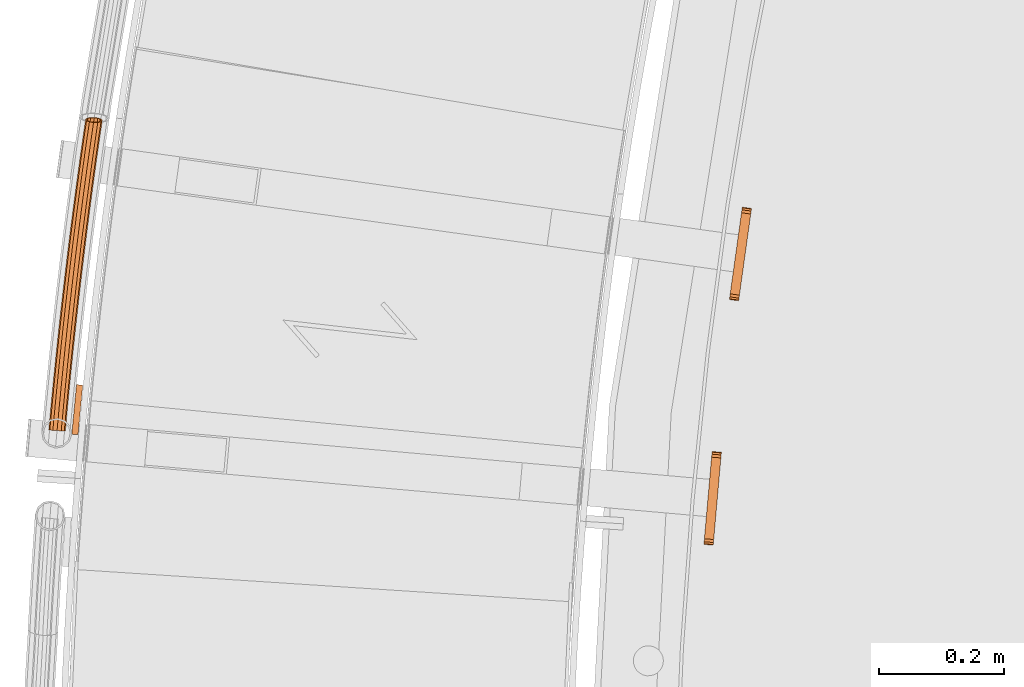
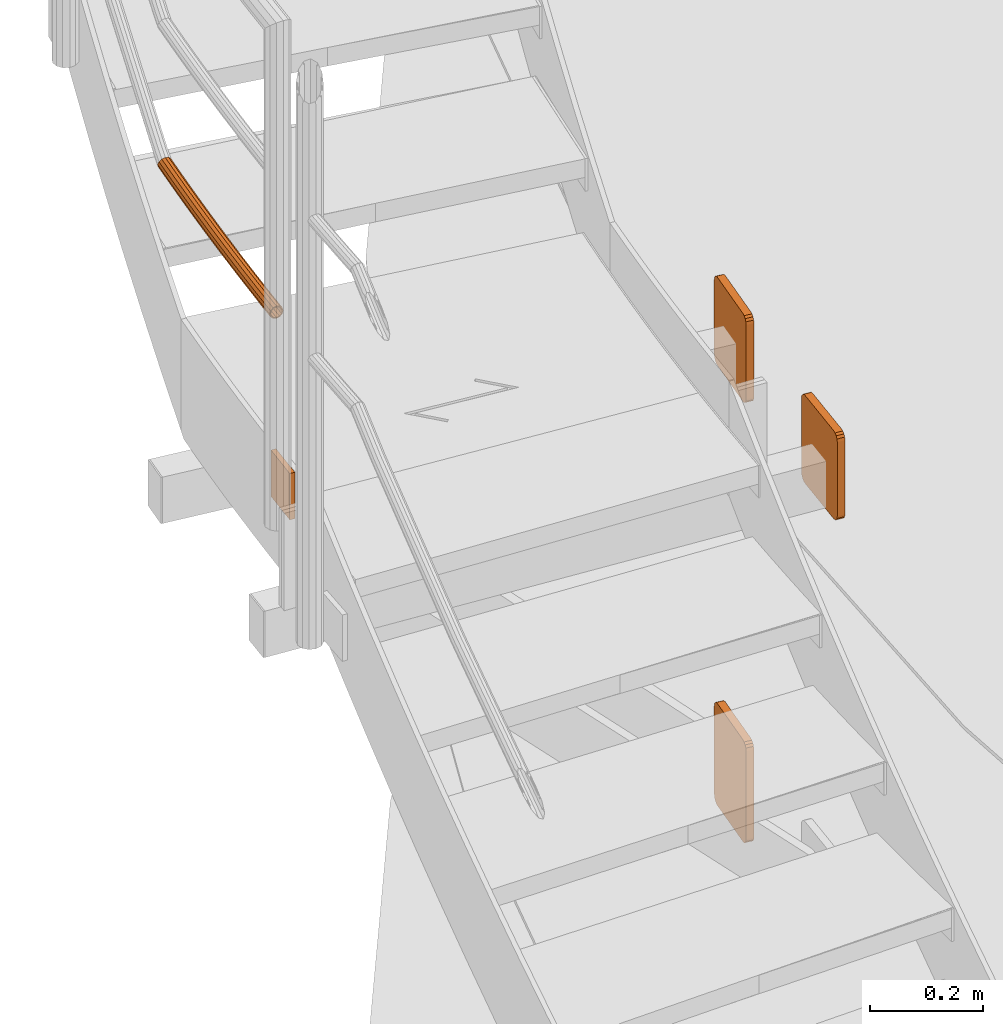
# One storey, part 60 of 126: 5 proxies.
"""IFC2X3 building model written with IfcOpenShell, lengths in millimetres."""

from ifc_helpers import new_model, si_unit, origin, origin_with_axes, place, context, project, spatial, faceted_brep, material, element, save


model = new_model("IFC2X3")

# Units and contexts
context_of_model_1 = context(None, 3, precision=0.1, world=origin())
context_of_model_2 = context(None, 3, precision=0.1, world=origin())
ifc_project = project(units=[si_unit("LENGTHUNIT", "METRE", prefix="MILLI"), si_unit("AREAUNIT", "SQUARE_METRE", prefix="CENTI"), si_unit("VOLUMEUNIT", "CUBIC_METRE", prefix="CENTI"), si_unit("MASSUNIT", "GRAM", prefix="KILO")], contexts=[context_of_model_1, context_of_model_2])

# Site, building, storey
site_placement = place(None, origin_with_axes())
site = spatial("IfcSite", under=ifc_project, at=site_placement, CompositionType="ELEMENT")
building_placement = place(site_placement, origin_with_axes())
building = spatial("IfcBuilding", under=site, at=building_placement, CompositionType="ELEMENT")
storey_placement = place(building_placement, origin_with_axes())
storey = spatial("IfcBuildingStorey", under=building, at=storey_placement, CompositionType="ELEMENT")

# Proxies
ifc_material = material(Name="S235JRG2")
proxy_1_placement = place(storey_placement, origin_with_axes())
element("IfcBuildingElementProxy", 1, at=proxy_1_placement, inside=storey, material=ifc_material, context=context_of_model_2, shape_type="Brep", body=[
    faceted_brep([(290.1448, 9142.2827, 5287.55), (290.9382, 9147.9679, 5288.6918), (291.6109, 9152.7875, 5291.9434), (292.0603, 9156.0079, 5296.8098), (292.2181, 9157.1387, 5302.55), (292.2181, 9157.1387, 5462.55), (292.0603, 9156.0079, 5468.2903), (291.6109, 9152.7875, 5473.1566), (290.9382, 9147.9679, 5476.4082), (290.1448, 9142.2827, 5477.55), (273.5581, 9023.4346, 5477.55), (272.7647, 9017.7494, 5476.4082), (272.092, 9012.9298, 5473.1566), (271.6426, 9009.7094, 5468.2903), (271.4848, 9008.5785, 5462.55), (271.4848, 9008.5785, 5302.55), (271.6426, 9009.7094, 5296.8098), (272.092, 9012.9298, 5291.9434), (272.7647, 9017.7494, 5288.6918), (273.5581, 9023.4346, 5287.55), (275.2888, 9144.356, 5287.55), (258.7021, 9025.5079, 5287.55), (257.9086, 9019.8228, 5288.6918), (257.236, 9015.0031, 5291.9434), (256.7866, 9011.7827, 5296.8098), (256.6287, 9010.6519, 5302.55), (256.6287, 9010.6519, 5462.55), (256.7866, 9011.7827, 5468.2903), (257.236, 9015.0031, 5473.1566), (257.9086, 9019.8228, 5476.4082), (258.7021, 9025.5079, 5477.55), (275.2888, 9144.356, 5477.55), (276.0822, 9150.0412, 5476.4082), (276.7548, 9154.8608, 5473.1566), (277.2043, 9158.0812, 5468.2903), (277.3621, 9159.2121, 5462.55), (277.3621, 9159.2121, 5302.55), (277.2043, 9158.0812, 5296.8098), (276.7548, 9154.8608, 5291.9434), (276.0822, 9150.0412, 5288.6918)], [[[0, 1, 2, 3, 4, 5, 6, 7, 8, 9, 10, 11, 12, 13, 14, 15, 16, 17, 18, 19]], [[20, 21, 22, 23, 24, 25, 26, 27, 28, 29, 30, 31, 32, 33, 34, 35, 36, 37, 38, 39]], [[0, 20, 39, 1]], [[1, 39, 38, 2]], [[2, 38, 37, 3]], [[3, 37, 36, 4]], [[4, 36, 35, 5]], [[5, 35, 34, 6]], [[6, 34, 33, 7]], [[7, 33, 32, 8]], [[8, 32, 31, 9]], [[9, 31, 30, 10]], [[10, 30, 29, 11]], [[11, 29, 28, 12]], [[12, 28, 27, 13]], [[13, 27, 26, 14]], [[14, 26, 25, 15]], [[15, 25, 24, 16]], [[16, 24, 23, 17]], [[17, 23, 22, 18]], [[18, 22, 21, 19]], [[19, 21, 20, 0]]]),
])
proxy_2_placement = place(storey_placement, origin_with_axes())
element("IfcBuildingElementProxy", 2, at=proxy_2_placement, inside=storey, material=ifc_material, context=context_of_model_2, shape_type="Brep", body=[
    faceted_brep([(290.1448, 9142.2827, 4337.8773), (290.9382, 9147.9679, 4339.0191), (291.6109, 9152.7875, 4342.2707), (292.0603, 9156.0079, 4347.137), (292.2181, 9157.1387, 4352.8773), (292.2181, 9157.1387, 4542.8773), (292.0603, 9156.0079, 4548.6175), (291.6109, 9152.7875, 4553.4839), (290.9382, 9147.9679, 4556.7355), (290.1448, 9142.2827, 4557.8773), (273.5581, 9023.4346, 4557.8773), (272.7647, 9017.7494, 4556.7355), (272.092, 9012.9298, 4553.4839), (271.6426, 9009.7094, 4548.6175), (271.4848, 9008.5785, 4542.8773), (271.4848, 9008.5785, 4352.8773), (271.6426, 9009.7094, 4347.137), (272.092, 9012.9298, 4342.2707), (272.7647, 9017.7494, 4339.0191), (273.5581, 9023.4346, 4337.8773), (275.2888, 9144.356, 4337.8773), (258.7021, 9025.5079, 4337.8773), (257.9086, 9019.8228, 4339.0191), (257.236, 9015.0031, 4342.2707), (256.7866, 9011.7827, 4347.137), (256.6287, 9010.6519, 4352.8773), (256.6287, 9010.6519, 4542.8773), (256.7866, 9011.7827, 4548.6175), (257.236, 9015.0031, 4553.4839), (257.9086, 9019.8228, 4556.7355), (258.7021, 9025.5079, 4557.8773), (275.2888, 9144.356, 4557.8773), (276.0822, 9150.0412, 4556.7355), (276.7548, 9154.8608, 4553.4839), (277.2043, 9158.0812, 4548.6175), (277.3621, 9159.2121, 4542.8773), (277.3621, 9159.2121, 4352.8773), (277.2043, 9158.0812, 4347.137), (276.7548, 9154.8608, 4342.2707), (276.0822, 9150.0412, 4339.0191)], [[[0, 1, 2, 3, 4, 5, 6, 7, 8, 9, 10, 11, 12, 13, 14, 15, 16, 17, 18, 19]], [[20, 21, 22, 23, 24, 25, 26, 27, 28, 29, 30, 31, 32, 33, 34, 35, 36, 37, 38, 39]], [[0, 20, 39, 1]], [[1, 39, 38, 2]], [[2, 38, 37, 3]], [[3, 37, 36, 4]], [[4, 36, 35, 5]], [[5, 35, 34, 6]], [[6, 34, 33, 7]], [[7, 33, 32, 8]], [[8, 32, 31, 9]], [[9, 31, 30, 10]], [[10, 30, 29, 11]], [[11, 29, 28, 12]], [[12, 28, 27, 13]], [[13, 27, 26, 14]], [[14, 26, 25, 15]], [[15, 25, 24, 16]], [[16, 24, 23, 17]], [[17, 23, 22, 18]], [[18, 22, 21, 19]], [[19, 21, 20, 0]]]),
])
proxy_3_placement = place(storey_placement, origin_with_axes())
element("IfcBuildingElementProxy", 3, at=proxy_3_placement, inside=storey, material=ifc_material, context=context_of_model_2, shape_type="Brep", body=[
    faceted_brep([(242.4863, 8750.5091, 5287.55), (242.9911, 8756.2271, 5288.6918), (243.419, 8761.0746, 5291.9434), (243.7049, 8764.3136, 5296.8098), (243.8054, 8765.4509, 5302.55), (243.8054, 8765.4509, 5462.55), (243.7049, 8764.3136, 5468.2903), (243.419, 8761.0746, 5473.1566), (242.9911, 8756.2271, 5476.4082), (242.4863, 8750.5091, 5477.55), (231.9337, 8630.9739, 5477.55), (231.4289, 8625.2559, 5476.4082), (231.001, 8620.4084, 5473.1566), (230.715, 8617.1694, 5468.2903), (230.6146, 8616.032, 5462.55), (230.6146, 8616.032, 5302.55), (230.715, 8617.1694, 5296.8098), (231.001, 8620.4084, 5291.9434), (231.4289, 8625.2559, 5288.6918), (231.9337, 8630.9739, 5287.55), (227.5444, 8751.8281, 5287.55), (216.9918, 8632.293, 5287.55), (216.487, 8626.575, 5288.6918), (216.0591, 8621.7275, 5291.9434), (215.7732, 8618.4885, 5296.8098), (215.6727, 8617.3511, 5302.55), (215.6727, 8617.3511, 5462.55), (215.7732, 8618.4885, 5468.2903), (216.0591, 8621.7275, 5473.1566), (216.487, 8626.575, 5476.4082), (216.9918, 8632.293, 5477.55), (227.5444, 8751.8281, 5477.55), (228.0492, 8757.5461, 5476.4082), (228.4771, 8762.3936, 5473.1566), (228.7631, 8765.6326, 5468.2903), (228.8635, 8766.77, 5462.55), (228.8635, 8766.77, 5302.55), (228.7631, 8765.6326, 5296.8098), (228.4771, 8762.3936, 5291.9434), (228.0492, 8757.5461, 5288.6918)], [[[0, 1, 2, 3, 4, 5, 6, 7, 8, 9, 10, 11, 12, 13, 14, 15, 16, 17, 18, 19]], [[20, 21, 22, 23, 24, 25, 26, 27, 28, 29, 30, 31, 32, 33, 34, 35, 36, 37, 38, 39]], [[0, 20, 39, 1]], [[1, 39, 38, 2]], [[2, 38, 37, 3]], [[3, 37, 36, 4]], [[4, 36, 35, 5]], [[5, 35, 34, 6]], [[6, 34, 33, 7]], [[7, 33, 32, 8]], [[8, 32, 31, 9]], [[9, 31, 30, 10]], [[10, 30, 29, 11]], [[11, 29, 28, 12]], [[12, 28, 27, 13]], [[13, 27, 26, 14]], [[14, 26, 25, 15]], [[15, 25, 24, 16]], [[16, 24, 23, 17]], [[17, 23, 22, 18]], [[18, 22, 21, 19]], [[19, 21, 20, 0]]]),
])
proxy_4_placement = place(storey_placement, origin_with_axes())
element("IfcBuildingElementProxy", 4, at=proxy_4_placement, inside=storey, material=ifc_material, context=context_of_model_2, shape_type="Brep", body=[
    faceted_brep([(-835.646, 8812.6734, 5995.5551), (-833.8515, 8812.5095, 5988.8301), (-834.8889, 8800.9315, 5988.8301), (-836.6876, 8801.0484, 5995.5551), (-828.9489, 8812.0616, 5983.907), (-829.9748, 8800.612, 5983.907), (-822.2518, 8811.4498, 5982.1051), (-823.262, 8800.1755, 5982.1051), (-815.5547, 8810.8379, 5983.907), (-816.5491, 8799.7391, 5983.907), (-810.652, 8810.39, 5988.8301), (-811.635, 8799.4196, 5988.8301), (-808.8575, 8810.2261, 5995.5551), (-809.8363, 8799.3026, 5995.5551), (-810.652, 8810.39, 6002.2801), (-811.635, 8799.4196, 6002.2801), (-815.5547, 8810.8379, 6007.2031), (-816.5491, 8799.7391, 6007.2031), (-822.2518, 8811.4498, 6009.0051), (-823.262, 8800.1755, 6009.0051), (-828.9489, 8812.0616, 6007.2031), (-829.9748, 8800.612, 6007.2031), (-833.8515, 8812.5095, 6002.2801), (-834.8889, 8800.9315, 6002.2801), (-833.6543, 8812.4915, 5995.5551), (-832.1267, 8812.3519, 6001.2801), (-833.16, 8800.8191, 6001.2801), (-834.6912, 8800.9186, 5995.5551), (-827.9531, 8811.9706, 6005.4711), (-828.9766, 8800.5471, 6005.4711), (-822.2518, 8811.4498, 6007.0051), (-823.262, 8800.1755, 6007.0051), (-816.5505, 8810.9289, 6005.4711), (-817.5473, 8799.804, 6005.4711), (-812.3769, 8810.5476, 6001.2801), (-813.3639, 8799.532, 6001.2801), (-810.8493, 8810.408, 5995.5551), (-811.8327, 8799.4324, 5995.5551), (-812.3769, 8810.5476, 5989.8301), (-813.3639, 8799.532, 5989.8301), (-816.5505, 8810.9289, 5985.6391), (-817.5473, 8799.804, 5985.6391), (-822.2518, 8811.4498, 5984.1051), (-823.262, 8800.1755, 5984.1051), (-827.9531, 8811.9706, 5985.6391), (-828.9766, 8800.5471, 5985.6391), (-832.1267, 8812.3519, 5989.8301), (-833.16, 8800.8191, 5989.8301), (-832.7729, 8843.5281, 5995.5551), (-830.979, 8843.3579, 5988.8301), (-826.0779, 8842.8929, 5983.907), (-819.383, 8842.2577, 5982.1051), (-812.688, 8841.6225, 5983.907), (-807.787, 8841.1575, 5988.8301), (-805.9931, 8840.9873, 5995.5551), (-807.787, 8841.1575, 6002.2801), (-812.688, 8841.6225, 6007.2031), (-819.383, 8842.2577, 6009.0051), (-826.0779, 8842.8929, 6007.2031), (-830.979, 8843.3579, 6002.2801), (-830.7818, 8843.3392, 5995.5551), (-829.2546, 8843.1943, 6001.2801), (-825.0824, 8842.7985, 6005.4711), (-819.383, 8842.2577, 6007.0051), (-813.6836, 8841.7169, 6005.4711), (-809.5113, 8841.3211, 6001.2801), (-807.9841, 8841.1762, 5995.5551), (-809.5113, 8841.3211, 5989.8301), (-813.6836, 8841.7169, 5985.6391), (-819.383, 8842.2577, 5984.1051), (-825.0824, 8842.7985, 5985.6391), (-829.2546, 8843.1943, 5989.8301), (-829.792, 8874.3726, 5995.5551), (-827.9987, 8874.1961, 5988.8301), (-823.0993, 8873.714, 5983.907), (-816.4066, 8873.0554, 5982.1051), (-809.714, 8872.3969, 5983.907), (-804.8146, 8871.9147, 5988.8301), (-803.0213, 8871.7383, 5995.5551), (-804.8146, 8871.9147, 6002.2801), (-809.714, 8872.3969, 6007.2031), (-816.4066, 8873.0554, 6009.0051), (-823.0993, 8873.714, 6007.2031), (-827.9987, 8874.1961, 6002.2801), (-827.8016, 8874.1767, 5995.5551), (-826.275, 8874.0265, 6001.2801), (-822.1041, 8873.6161, 6005.4711), (-816.4066, 8873.0554, 6007.0051), (-810.7091, 8872.4948, 6005.4711), (-806.5383, 8872.0844, 6001.2801), (-805.0117, 8871.9341, 5995.5551), (-806.5383, 8872.0844, 5989.8301), (-810.7091, 8872.4948, 5985.6391), (-816.4066, 8873.0554, 5984.1051), (-822.1041, 8873.6161, 5985.6391), (-826.275, 8874.0265, 5989.8301), (-826.7035, 8905.2065, 5995.5551), (-824.9108, 8905.0238, 5988.8301), (-820.0132, 8904.5246, 5983.907), (-813.3228, 8903.8426, 5982.1051), (-806.6325, 8903.1607, 5983.907), (-801.7348, 8902.6615, 5988.8301), (-799.9421, 8902.4787, 5995.5551), (-801.7348, 8902.6615, 6002.2801), (-806.6325, 8903.1607, 6007.2031), (-813.3228, 8903.8426, 6009.0051), (-820.0132, 8904.5246, 6007.2031), (-824.9108, 8905.0238, 6002.2801), (-824.7138, 8905.0037, 5995.5551), (-823.1877, 8904.8481, 6001.2801), (-819.0183, 8904.4231, 6005.4711), (-813.3228, 8903.8426, 6007.0051), (-807.6273, 8903.2621, 6005.4711), (-803.4579, 8902.8371, 6001.2801), (-801.9318, 8902.6815, 5995.5551), (-803.4579, 8902.8371, 5989.8301), (-807.6273, 8903.2621, 5985.6391), (-813.3228, 8903.8426, 5984.1051), (-819.0183, 8904.4231, 5985.6391), (-823.1877, 8904.8481, 5989.8301), (-823.5074, 8936.0294, 5995.5551), (-821.7154, 8935.8404, 5988.8301), (-816.8195, 8935.3241, 5983.907), (-810.1315, 8934.6188, 5982.1051), (-803.4436, 8933.9135, 5983.907), (-798.5477, 8933.3972, 5988.8301), (-796.7557, 8933.2082, 5995.5551), (-798.5477, 8933.3972, 6002.2801), (-803.4436, 8933.9135, 6007.2031), (-810.1315, 8934.6188, 6009.0051), (-816.8195, 8935.3241, 6007.2031), (-821.7154, 8935.8404, 6002.2801), (-821.5184, 8935.8197, 5995.5551), (-819.9929, 8935.6588, 6001.2801), (-815.825, 8935.2192, 6005.4711), (-810.1315, 8934.6188, 6007.0051), (-804.4381, 8934.0184, 6005.4711), (-800.2702, 8933.5789, 6001.2801), (-798.7447, 8933.418, 5995.5551), (-800.2702, 8933.5789, 5989.8301), (-804.4381, 8934.0184, 5985.6391), (-810.1315, 8934.6188, 5984.1051), (-815.825, 8935.2192, 5985.6391), (-819.9929, 8935.6588, 5989.8301), (-820.2037, 8966.841, 5995.5551), (-818.4124, 8966.6457, 5988.8301), (-813.5183, 8966.1123, 5983.907), (-806.8329, 8965.3837, 5982.1051), (-800.1474, 8964.6551, 5983.907), (-795.2534, 8964.1217, 5988.8301), (-793.462, 8963.9265, 5995.5551), (-795.2534, 8964.1217, 6002.2801), (-800.1474, 8964.6551, 6007.2031), (-806.8329, 8965.3837, 6009.0051), (-813.5183, 8966.1123, 6007.2031), (-818.4124, 8966.6457, 6002.2801), (-818.2155, 8966.6243, 5995.5551), (-816.6905, 8966.4581, 6001.2801), (-812.5242, 8966.004, 6005.4711), (-806.8329, 8965.3837, 6007.0051), (-801.1416, 8964.7634, 6005.4711), (-796.9752, 8964.3094, 6001.2801), (-795.4503, 8964.1431, 5995.5551), (-796.9752, 8964.3094, 5989.8301), (-801.1416, 8964.7634, 5985.6391), (-806.8329, 8965.3837, 5984.1051), (-812.5242, 8966.004, 5985.6391), (-816.6905, 8966.4581, 5989.8301), (-816.7925, 8997.6408, 5995.5551), (-815.0018, 8997.4393, 5988.8301), (-810.1097, 8996.8889, 5983.907), (-803.4268, 8996.1369, 5982.1051), (-796.744, 8995.3849, 5983.907), (-791.8518, 8994.8345, 5988.8301), (-790.0611, 8994.633, 5995.5551), (-791.8518, 8994.8345, 6002.2801), (-796.744, 8995.3849, 6007.2031), (-803.4268, 8996.1369, 6009.0051), (-810.1097, 8996.8889, 6007.2031), (-815.0018, 8997.4393, 6002.2801), (-814.805, 8997.4172, 5995.5551), (-813.2806, 8997.2457, 6001.2801), (-809.1159, 8996.777, 6005.4711), (-803.4268, 8996.1369, 6007.0051), (-797.7377, 8995.4968, 6005.4711), (-793.573, 8995.0281, 6001.2801), (-792.0486, 8994.8566, 5995.5551), (-793.573, 8995.0281, 5989.8301), (-797.7377, 8995.4968, 5985.6391), (-803.4268, 8996.1369, 5984.1051), (-809.1159, 8996.777, 5985.6391), (-813.2806, 8997.2457, 5989.8301), (-813.2738, 9028.4286, 5995.5551), (-811.4838, 9028.2208, 5988.8301), (-806.5936, 9027.6533, 5983.907), (-799.9134, 9026.878, 5982.1051), (-793.2333, 9026.1027, 5983.907), (-788.343, 9025.5352, 5988.8301), (-786.5531, 9025.3274, 5995.5551), (-788.343, 9025.5352, 6002.2801), (-793.2333, 9026.1027, 6007.2031), (-799.9134, 9026.878, 6009.0051), (-806.5936, 9027.6533, 6007.2031), (-811.4838, 9028.2208, 6002.2801), (-811.2871, 9028.198, 5995.5551), (-809.7633, 9028.0212, 6001.2801), (-805.6003, 9027.538, 6005.4711), (-799.9134, 9026.878, 6007.0051), (-794.2266, 9026.218, 6005.4711), (-790.0635, 9025.7349, 6001.2801), (-788.5398, 9025.558, 5995.5551), (-790.0635, 9025.7349, 5989.8301), (-794.2266, 9026.218, 5985.6391), (-799.9134, 9026.878, 5984.1051), (-805.6003, 9027.538, 5985.6391), (-809.7633, 9028.0212, 5989.8301), (-809.6476, 9059.2039, 5995.5551), (-807.8584, 9058.9899, 5988.8301), (-802.9702, 9058.4053, 5983.907), (-796.2928, 9057.6067, 5982.1051), (-789.6154, 9056.8081, 5983.907), (-784.7271, 9056.2235, 5988.8301), (-782.9379, 9056.0095, 5995.5551), (-784.7271, 9056.2235, 6002.2801), (-789.6154, 9056.8081, 6007.2031), (-796.2928, 9057.6067, 6009.0051), (-802.9702, 9058.4053, 6007.2031), (-807.8584, 9058.9899, 6002.2801), (-807.6618, 9058.9664, 5995.5551), (-806.1386, 9058.7842, 6001.2801), (-801.9773, 9058.2865, 6005.4711), (-796.2928, 9057.6067, 6007.0051), (-790.6083, 9056.9268, 6005.4711), (-786.4469, 9056.4291, 6001.2801), (-784.9238, 9056.247, 5995.5551), (-786.4469, 9056.4291, 5989.8301), (-790.6083, 9056.9268, 5985.6391), (-796.2928, 9057.6067, 5984.1051), (-801.9773, 9058.2865, 5985.6391), (-806.1386, 9058.7842, 5989.8301), (-805.9141, 9089.9663, 5995.5551), (-804.1256, 9089.7461, 5988.8301), (-799.2395, 9089.1444, 5983.907), (-792.5649, 9088.3225, 5982.1051), (-785.8903, 9087.5006, 5983.907), (-781.0041, 9086.8989, 5988.8301), (-779.2157, 9086.6787, 5995.5551), (-781.0041, 9086.8989, 6002.2801), (-785.8903, 9087.5006, 6007.2031), (-792.5649, 9088.3225, 6009.0051), (-799.2395, 9089.1444, 6007.2031), (-804.1256, 9089.7461, 6002.2801), (-803.9291, 9089.7219, 5995.5551), (-802.4065, 9089.5344, 6001.2801), (-798.247, 9089.0222, 6005.4711), (-792.5649, 9088.3225, 6007.0051), (-786.8828, 9087.6228, 6005.4711), (-782.7232, 9087.1106, 6001.2801), (-781.2007, 9086.9231, 5995.5551), (-782.7232, 9087.1106, 5989.8301), (-786.8828, 9087.6228, 5985.6391), (-792.5649, 9088.3225, 5984.1051), (-798.247, 9089.0222, 5985.6391), (-802.4065, 9089.5344, 5989.8301), (-802.0731, 9120.7155, 5995.5551), (-800.2855, 9120.4891, 5988.8301), (-795.4015, 9119.8703, 5983.907), (-788.7298, 9119.0251, 5982.1051), (-782.0581, 9118.1799, 5983.907), (-777.1741, 9117.5612, 5988.8301), (-775.3864, 9117.3347, 5995.5551), (-777.1741, 9117.5612, 6002.2801), (-782.0581, 9118.1799, 6007.2031), (-788.7298, 9119.0251, 6009.0051), (-795.4015, 9119.8703, 6007.2031), (-800.2855, 9120.4891, 6002.2801), (-800.089, 9120.4642, 5995.5551), (-798.5672, 9120.2714, 6001.2801), (-794.4094, 9119.7446, 6005.4711), (-788.7298, 9119.0251, 6007.0051), (-783.0502, 9118.3056, 6005.4711), (-778.8924, 9117.7789, 6001.2801), (-777.3705, 9117.5861, 5995.5551), (-778.8924, 9117.7789, 5989.8301), (-783.0502, 9118.3056, 5985.6391), (-788.7298, 9119.0251, 5984.1051), (-794.4094, 9119.7446, 5985.6391), (-798.5672, 9120.2714, 5989.8301), (-798.1249, 9151.4512, 5995.5551), (-796.338, 9151.2184, 5988.8301), (-791.4562, 9150.5827, 5983.907), (-784.7875, 9149.7142, 5982.1051), (-778.1188, 9148.8457, 5983.907), (-773.237, 9148.2099, 5988.8301), (-771.4501, 9147.9772, 5995.5551), (-773.237, 9148.2099, 6002.2801), (-778.1188, 9148.8457, 6007.2031), (-784.7875, 9149.7142, 6009.0051), (-791.4562, 9150.5827, 6007.2031), (-796.338, 9151.2184, 6002.2801), (-796.1417, 9151.1929, 5995.5551), (-794.6205, 9150.9948, 6001.2801), (-790.4646, 9150.4535, 6005.4711), (-784.7875, 9149.7142, 6007.0051), (-779.1105, 9148.9749, 6005.4711), (-774.9546, 9148.4336, 6001.2801), (-773.4334, 9148.2355, 5995.5551), (-774.9546, 9148.4336, 5989.8301), (-779.1105, 9148.9749, 5985.6391), (-784.7875, 9149.7142, 5984.1051), (-790.4646, 9150.4535, 5985.6391), (-794.6205, 9150.9948, 5989.8301), (-794.0694, 9182.1728, 5995.5551), (-792.2834, 9181.9339, 5988.8301), (-787.4038, 9181.2811, 5983.907), (-780.7382, 9180.3893, 5982.1051), (-774.0726, 9179.4975, 5983.907), (-769.193, 9178.8447, 5988.8301), (-767.4069, 9178.6058, 5995.5551), (-769.193, 9178.8447, 6002.2801), (-774.0726, 9179.4975, 6007.2031), (-780.7382, 9180.3893, 6009.0051), (-787.4038, 9181.2811, 6007.2031), (-792.2834, 9181.9339, 6002.2801), (-792.0871, 9181.9076, 5995.5551), (-790.5666, 9181.7042, 6001.2801), (-786.4126, 9181.1485, 6005.4711), (-780.7382, 9180.3893, 6007.0051), (-775.0637, 9179.6302, 6005.4711), (-770.9097, 9179.0744, 6001.2801), (-769.3893, 9178.871, 5995.5551), (-770.9097, 9179.0744, 5989.8301), (-775.0637, 9179.6302, 5985.6391), (-780.7382, 9180.3893, 5984.1051), (-786.4126, 9181.1485, 5985.6391), (-790.5666, 9181.7042, 5989.8301), (-789.9067, 9212.8801, 5995.5551), (-788.1215, 9212.6349, 5988.8301), (-783.2442, 9211.9651, 5983.907), (-776.5818, 9211.0501, 5982.1051), (-769.9193, 9210.1351, 5983.907), (-765.042, 9209.4652, 5988.8301), (-763.2568, 9209.2201, 5995.5551), (-765.042, 9209.4652, 6002.2801), (-769.9193, 9210.1351, 6007.2031), (-776.5818, 9211.0501, 6009.0051), (-783.2442, 9211.9651, 6007.2031), (-788.1215, 9212.6349, 6002.2801), (-787.9253, 9212.608, 5995.5551), (-786.4056, 9212.3993, 6001.2801), (-782.2535, 9211.829, 6005.4711), (-776.5818, 9211.0501, 6007.0051), (-770.91, 9210.2711, 6005.4711), (-766.758, 9209.7009, 6001.2801), (-765.2382, 9209.4922, 5995.5551), (-766.758, 9209.7009, 5989.8301), (-770.91, 9210.2711, 5985.6391), (-776.5818, 9211.0501, 5984.1051), (-782.2535, 9211.829, 5985.6391), (-786.4056, 9212.3993, 5989.8301), (-785.6368, 9243.5727, 5995.5551), (-783.8525, 9243.3213, 5988.8301), (-778.9776, 9242.6344, 5983.907), (-772.3184, 9241.6962, 5982.1051), (-765.6591, 9240.7579, 5983.907), (-760.7842, 9240.0711, 5988.8301), (-758.9999, 9239.8197, 5995.5551), (-760.7842, 9240.0711, 6002.2801), (-765.6591, 9240.7579, 6007.2031), (-772.3184, 9241.6962, 6009.0051), (-778.9776, 9242.6344, 6007.2031), (-783.8525, 9243.3213, 6002.2801), (-783.6564, 9243.2937, 5995.5551), (-782.1374, 9243.0797, 6001.2801), (-777.9874, 9242.4949, 6005.4711), (-772.3184, 9241.6962, 6007.0051), (-766.6494, 9240.8974, 6005.4711), (-762.4994, 9240.3127, 6001.2801), (-760.9803, 9240.0987, 5995.5551), (-762.4994, 9240.3127, 5989.8301), (-766.6494, 9240.8974, 5985.6391), (-772.3184, 9241.6962, 5984.1051), (-777.9874, 9242.4949, 5985.6391), (-782.1374, 9243.0797, 5989.8301), (-781.2599, 9274.2502, 5995.5551), (-779.4764, 9273.9926, 5988.8301), (-774.6039, 9273.2887, 5983.907), (-767.948, 9272.3272, 5982.1051), (-761.2921, 9271.3657, 5983.907), (-756.4196, 9270.6618, 5988.8301), (-754.6362, 9270.4042, 5995.5551), (-756.4196, 9270.6618, 6002.2801), (-761.2921, 9271.3657, 6007.2031), (-767.948, 9272.3272, 6009.0051), (-774.6039, 9273.2887, 6007.2031), (-779.4764, 9273.9926, 6002.2801), (-779.2804, 9273.9643, 5995.5551), (-777.7622, 9273.7449, 6001.2801), (-773.6142, 9273.1457, 6005.4711), (-767.948, 9272.3272, 6007.0051), (-762.2818, 9271.5087, 6005.4711), (-758.1339, 9270.9095, 6001.2801), (-756.6156, 9270.6901, 5995.5551), (-758.1339, 9270.9095, 5989.8301), (-762.2818, 9271.5087, 5985.6391), (-767.948, 9272.3272, 5984.1051), (-773.6142, 9273.1457, 5985.6391), (-777.7622, 9273.7449, 5989.8301), (-777.4914, 9300.0193, 5995.5551), (-775.3786, 9302.0135, 5988.8301), (-770.224, 9303.2388, 5983.907), (-766.0059, 9303.3181, 5982.7918), (-763.4708, 9302.9428, 5982.1051), (-756.8183, 9301.9581, 5983.907), (-755.0949, 9301.703, 5985.6492), (-752.0565, 9300.4972, 5988.8301), (-750.5613, 9298.2684, 5995.5551), (-752.6741, 9296.2742, 6002.2801), (-757.8287, 9295.0489, 6007.2031), (-764.6439, 9294.9209, 6009.0051), (-771.2937, 9295.9244, 6007.2031), (-775.9962, 9297.7906, 6002.2801), (-775.4891, 9299.8892, 5995.5551), (-774.2163, 9297.9918, 6001.2801), (-770.213, 9296.4031, 6005.4711), (-764.5521, 9295.5488, 6007.0051), (-758.7502, 9295.6578, 6005.4711), (-754.3621, 9296.7009, 6001.2801), (-752.5635, 9298.3986, 5995.5551), (-753.8364, 9300.2959, 5989.8301), (-757.8396, 9301.8846, 5985.6391), (-763.5006, 9302.7389, 5984.1051), (-769.3024, 9302.6299, 5985.6391), (-773.6905, 9301.5868, 5989.8301), (-763.4073, 9303.3668, 5982.1051), (-756.7576, 9302.3633, 5983.907)], [[[0, 1, 2, 3]], [[1, 4, 5, 2]], [[4, 6, 7, 5]], [[6, 8, 9, 7]], [[8, 10, 11, 9]], [[10, 12, 13, 11]], [[12, 14, 15, 13]], [[14, 16, 17, 15]], [[16, 18, 19, 17]], [[18, 20, 21, 19]], [[20, 22, 23, 21]], [[0, 3, 23, 22]], [[24, 25, 26, 27]], [[25, 28, 29, 26]], [[28, 30, 31, 29]], [[30, 32, 33, 31]], [[32, 34, 35, 33]], [[34, 36, 37, 35]], [[36, 38, 39, 37]], [[38, 40, 41, 39]], [[40, 42, 43, 41]], [[42, 44, 45, 43]], [[44, 46, 47, 45]], [[24, 27, 47, 46]], [[0, 48, 49, 1]], [[1, 49, 50, 4]], [[4, 50, 51, 6]], [[6, 51, 52, 8]], [[8, 52, 53, 10]], [[10, 53, 54, 12]], [[12, 54, 55, 14]], [[14, 55, 56, 16]], [[16, 56, 57, 18]], [[18, 57, 58, 20]], [[20, 58, 59, 22]], [[22, 59, 48, 0]], [[24, 60, 61, 25]], [[25, 61, 62, 28]], [[28, 62, 63, 30]], [[30, 63, 64, 32]], [[32, 64, 65, 34]], [[34, 65, 66, 36]], [[36, 66, 67, 38]], [[38, 67, 68, 40]], [[40, 68, 69, 42]], [[42, 69, 70, 44]], [[44, 70, 71, 46]], [[46, 71, 60, 24]], [[48, 72, 73, 49]], [[49, 73, 74, 50]], [[50, 74, 75, 51]], [[51, 75, 76, 52]], [[52, 76, 77, 53]], [[53, 77, 78, 54]], [[54, 78, 79, 55]], [[55, 79, 80, 56]], [[56, 80, 81, 57]], [[57, 81, 82, 58]], [[58, 82, 83, 59]], [[59, 83, 72, 48]], [[60, 84, 85, 61]], [[61, 85, 86, 62]], [[62, 86, 87, 63]], [[63, 87, 88, 64]], [[64, 88, 89, 65]], [[65, 89, 90, 66]], [[66, 90, 91, 67]], [[67, 91, 92, 68]], [[68, 92, 93, 69]], [[69, 93, 94, 70]], [[70, 94, 95, 71]], [[71, 95, 84, 60]], [[72, 96, 97, 73]], [[73, 97, 98, 74]], [[74, 98, 99, 75]], [[75, 99, 100, 76]], [[76, 100, 101, 77]], [[77, 101, 102, 78]], [[78, 102, 103, 79]], [[79, 103, 104, 80]], [[80, 104, 105, 81]], [[81, 105, 106, 82]], [[82, 106, 107, 83]], [[83, 107, 96, 72]], [[84, 108, 109, 85]], [[85, 109, 110, 86]], [[86, 110, 111, 87]], [[87, 111, 112, 88]], [[88, 112, 113, 89]], [[89, 113, 114, 90]], [[90, 114, 115, 91]], [[91, 115, 116, 92]], [[92, 116, 117, 93]], [[93, 117, 118, 94]], [[94, 118, 119, 95]], [[95, 119, 108, 84]], [[96, 120, 121, 97]], [[97, 121, 122, 98]], [[98, 122, 123, 99]], [[99, 123, 124, 100]], [[100, 124, 125, 101]], [[101, 125, 126, 102]], [[102, 126, 127, 103]], [[103, 127, 128, 104]], [[104, 128, 129, 105]], [[105, 129, 130, 106]], [[106, 130, 131, 107]], [[107, 131, 120, 96]], [[108, 132, 133, 109]], [[109, 133, 134, 110]], [[110, 134, 135, 111]], [[111, 135, 136, 112]], [[112, 136, 137, 113]], [[113, 137, 138, 114]], [[114, 138, 139, 115]], [[115, 139, 140, 116]], [[116, 140, 141, 117]], [[117, 141, 142, 118]], [[118, 142, 143, 119]], [[119, 143, 132, 108]], [[120, 144, 145, 121]], [[121, 145, 146, 122]], [[122, 146, 147, 123]], [[123, 147, 148, 124]], [[124, 148, 149, 125]], [[125, 149, 150, 126]], [[126, 150, 151, 127]], [[127, 151, 152, 128]], [[128, 152, 153, 129]], [[129, 153, 154, 130]], [[130, 154, 155, 131]], [[131, 155, 144, 120]], [[132, 156, 157, 133]], [[133, 157, 158, 134]], [[134, 158, 159, 135]], [[135, 159, 160, 136]], [[136, 160, 161, 137]], [[137, 161, 162, 138]], [[138, 162, 163, 139]], [[139, 163, 164, 140]], [[140, 164, 165, 141]], [[141, 165, 166, 142]], [[142, 166, 167, 143]], [[143, 167, 156, 132]], [[144, 168, 169, 145]], [[145, 169, 170, 146]], [[146, 170, 171, 147]], [[147, 171, 172, 148]], [[148, 172, 173, 149]], [[149, 173, 174, 150]], [[150, 174, 175, 151]], [[151, 175, 176, 152]], [[152, 176, 177, 153]], [[153, 177, 178, 154]], [[154, 178, 179, 155]], [[155, 179, 168, 144]], [[156, 180, 181, 157]], [[157, 181, 182, 158]], [[158, 182, 183, 159]], [[159, 183, 184, 160]], [[160, 184, 185, 161]], [[161, 185, 186, 162]], [[162, 186, 187, 163]], [[163, 187, 188, 164]], [[164, 188, 189, 165]], [[165, 189, 190, 166]], [[166, 190, 191, 167]], [[167, 191, 180, 156]], [[168, 192, 193, 169]], [[169, 193, 194, 170]], [[170, 194, 195, 171]], [[171, 195, 196, 172]], [[172, 196, 197, 173]], [[173, 197, 198, 174]], [[174, 198, 199, 175]], [[175, 199, 200, 176]], [[176, 200, 201, 177]], [[177, 201, 202, 178]], [[178, 202, 203, 179]], [[179, 203, 192, 168]], [[180, 204, 205, 181]], [[181, 205, 206, 182]], [[182, 206, 207, 183]], [[183, 207, 208, 184]], [[184, 208, 209, 185]], [[185, 209, 210, 186]], [[186, 210, 211, 187]], [[187, 211, 212, 188]], [[188, 212, 213, 189]], [[189, 213, 214, 190]], [[190, 214, 215, 191]], [[191, 215, 204, 180]], [[192, 216, 217, 193]], [[193, 217, 218, 194]], [[194, 218, 219, 195]], [[195, 219, 220, 196]], [[196, 220, 221, 197]], [[197, 221, 222, 198]], [[198, 222, 223, 199]], [[199, 223, 224, 200]], [[200, 224, 225, 201]], [[201, 225, 226, 202]], [[202, 226, 227, 203]], [[203, 227, 216, 192]], [[204, 228, 229, 205]], [[205, 229, 230, 206]], [[206, 230, 231, 207]], [[207, 231, 232, 208]], [[208, 232, 233, 209]], [[209, 233, 234, 210]], [[210, 234, 235, 211]], [[211, 235, 236, 212]], [[212, 236, 237, 213]], [[213, 237, 238, 214]], [[214, 238, 239, 215]], [[215, 239, 228, 204]], [[216, 240, 241, 217]], [[217, 241, 242, 218]], [[218, 242, 243, 219]], [[219, 243, 244, 220]], [[220, 244, 245, 221]], [[221, 245, 246, 222]], [[222, 246, 247, 223]], [[223, 247, 248, 224]], [[224, 248, 249, 225]], [[225, 249, 250, 226]], [[226, 250, 251, 227]], [[227, 251, 240, 216]], [[228, 252, 253, 229]], [[229, 253, 254, 230]], [[230, 254, 255, 231]], [[231, 255, 256, 232]], [[232, 256, 257, 233]], [[233, 257, 258, 234]], [[234, 258, 259, 235]], [[235, 259, 260, 236]], [[236, 260, 261, 237]], [[237, 261, 262, 238]], [[238, 262, 263, 239]], [[239, 263, 252, 228]], [[240, 264, 265, 241]], [[241, 265, 266, 242]], [[242, 266, 267, 243]], [[243, 267, 268, 244]], [[244, 268, 269, 245]], [[245, 269, 270, 246]], [[246, 270, 271, 247]], [[247, 271, 272, 248]], [[248, 272, 273, 249]], [[249, 273, 274, 250]], [[250, 274, 275, 251]], [[251, 275, 264, 240]], [[252, 276, 277, 253]], [[253, 277, 278, 254]], [[254, 278, 279, 255]], [[255, 279, 280, 256]], [[256, 280, 281, 257]], [[257, 281, 282, 258]], [[258, 282, 283, 259]], [[259, 283, 284, 260]], [[260, 284, 285, 261]], [[261, 285, 286, 262]], [[262, 286, 287, 263]], [[263, 287, 276, 252]], [[264, 288, 289, 265]], [[265, 289, 290, 266]], [[266, 290, 291, 267]], [[267, 291, 292, 268]], [[268, 292, 293, 269]], [[269, 293, 294, 270]], [[270, 294, 295, 271]], [[271, 295, 296, 272]], [[272, 296, 297, 273]], [[273, 297, 298, 274]], [[274, 298, 299, 275]], [[275, 299, 288, 264]], [[276, 300, 301, 277]], [[277, 301, 302, 278]], [[278, 302, 303, 279]], [[279, 303, 304, 280]], [[280, 304, 305, 281]], [[281, 305, 306, 282]], [[282, 306, 307, 283]], [[283, 307, 308, 284]], [[284, 308, 309, 285]], [[285, 309, 310, 286]], [[286, 310, 311, 287]], [[287, 311, 300, 276]], [[288, 312, 313, 289]], [[289, 313, 314, 290]], [[290, 314, 315, 291]], [[291, 315, 316, 292]], [[292, 316, 317, 293]], [[293, 317, 318, 294]], [[294, 318, 319, 295]], [[295, 319, 320, 296]], [[296, 320, 321, 297]], [[297, 321, 322, 298]], [[298, 322, 323, 299]], [[299, 323, 312, 288]], [[300, 324, 325, 301]], [[301, 325, 326, 302]], [[302, 326, 327, 303]], [[303, 327, 328, 304]], [[304, 328, 329, 305]], [[305, 329, 330, 306]], [[306, 330, 331, 307]], [[307, 331, 332, 308]], [[308, 332, 333, 309]], [[309, 333, 334, 310]], [[310, 334, 335, 311]], [[311, 335, 324, 300]], [[312, 336, 337, 313]], [[313, 337, 338, 314]], [[314, 338, 339, 315]], [[315, 339, 340, 316]], [[316, 340, 341, 317]], [[317, 341, 342, 318]], [[318, 342, 343, 319]], [[319, 343, 344, 320]], [[320, 344, 345, 321]], [[321, 345, 346, 322]], [[322, 346, 347, 323]], [[323, 347, 336, 312]], [[324, 348, 349, 325]], [[325, 349, 350, 326]], [[326, 350, 351, 327]], [[327, 351, 352, 328]], [[328, 352, 353, 329]], [[329, 353, 354, 330]], [[330, 354, 355, 331]], [[331, 355, 356, 332]], [[332, 356, 357, 333]], [[333, 357, 358, 334]], [[334, 358, 359, 335]], [[335, 359, 348, 324]], [[336, 360, 361, 337]], [[337, 361, 362, 338]], [[338, 362, 363, 339]], [[339, 363, 364, 340]], [[340, 364, 365, 341]], [[341, 365, 366, 342]], [[342, 366, 367, 343]], [[343, 367, 368, 344]], [[344, 368, 369, 345]], [[345, 369, 370, 346]], [[346, 370, 371, 347]], [[347, 371, 360, 336]], [[348, 372, 373, 349]], [[349, 373, 374, 350]], [[350, 374, 375, 351]], [[351, 375, 376, 352]], [[352, 376, 377, 353]], [[353, 377, 378, 354]], [[354, 378, 379, 355]], [[355, 379, 380, 356]], [[356, 380, 381, 357]], [[357, 381, 382, 358]], [[358, 382, 383, 359]], [[359, 383, 372, 348]], [[360, 384, 385, 361]], [[361, 385, 386, 362]], [[362, 386, 387, 363]], [[363, 387, 388, 364]], [[364, 388, 389, 365]], [[365, 389, 390, 366]], [[366, 390, 391, 367]], [[367, 391, 392, 368]], [[368, 392, 393, 369]], [[369, 393, 394, 370]], [[370, 394, 395, 371]], [[371, 395, 384, 360]], [[372, 396, 397, 373]], [[373, 397, 398, 374]], [[374, 398, 399, 375]], [[375, 399, 400, 376]], [[376, 400, 401, 377]], [[377, 401, 402, 378]], [[378, 402, 403, 379]], [[379, 403, 404, 380]], [[380, 404, 405, 381]], [[381, 405, 406, 382]], [[382, 406, 407, 383]], [[383, 407, 396, 372]], [[384, 408, 409, 385]], [[385, 409, 410, 386]], [[386, 410, 411, 412, 387]], [[387, 412, 413, 388]], [[388, 413, 414, 415, 389]], [[389, 415, 416, 390]], [[390, 416, 417, 391]], [[391, 417, 418, 392]], [[392, 418, 419, 393]], [[393, 419, 420, 394]], [[394, 420, 421, 395]], [[384, 395, 421, 408]], [[396, 422, 423, 397]], [[397, 423, 424, 398]], [[398, 424, 425, 399]], [[399, 425, 426, 400]], [[400, 426, 427, 401]], [[401, 427, 428, 402]], [[402, 428, 429, 403]], [[403, 429, 430, 404]], [[404, 430, 431, 405]], [[405, 431, 432, 406]], [[406, 432, 433, 407]], [[396, 407, 433, 422]], [[411, 434, 412]], [[412, 434, 435, 413]], [[413, 435, 414]], [[7, 9, 11, 13, 15, 17, 19, 21, 23, 3, 2, 5], [26, 29, 31, 33, 35, 37, 39, 41, 43, 45, 47, 27]], [[408, 421, 420, 419, 418, 417, 416, 415, 414, 435, 434, 411, 410, 409], [422, 433, 432, 431, 430, 429, 428, 427, 426, 425, 424, 423]]]),
])
proxy_5_placement = place(storey_placement, origin_with_axes())
element("IfcBuildingElementProxy", 5, at=proxy_5_placement, inside=storey, material=ifc_material, Name="HANDLAUF", context=context_of_model_2, shape_type="Brep", body=[
    faceted_brep([(-789.5783, 8793.5265, 5542.55), (-799.5333, 8794.474, 5542.55), (-791.9531, 8874.1141, 5542.55), (-781.9981, 8873.1665, 5542.55), (-789.5783, 8793.5265, 5642.55), (-781.9981, 8873.1665, 5642.55), (-791.9531, 8874.1141, 5642.55), (-799.5333, 8794.474, 5642.55)], [[[0, 1, 2, 3]], [[4, 5, 6, 7]], [[0, 4, 7, 1]], [[1, 7, 6, 2]], [[2, 6, 5, 3]], [[3, 5, 4, 0]]]),
])

save(model, "model.ifc")
